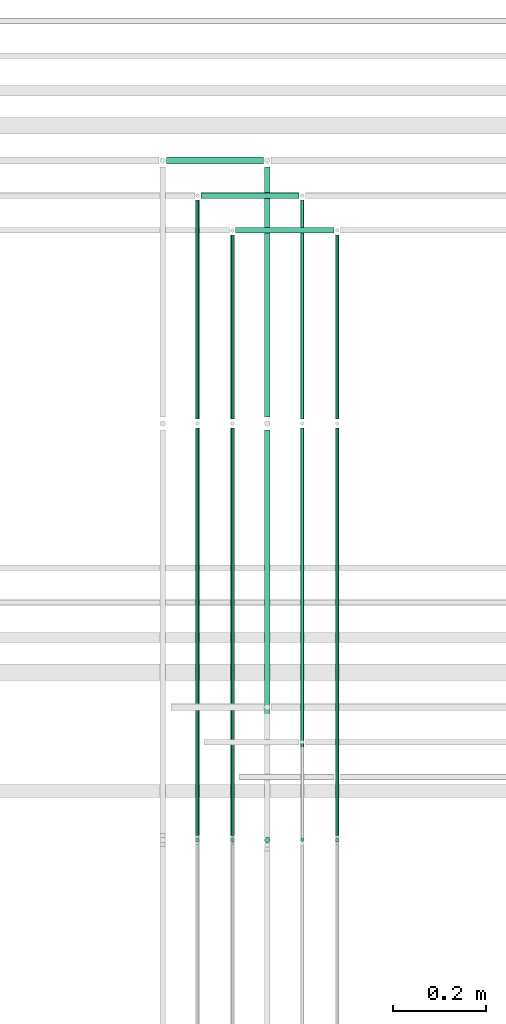
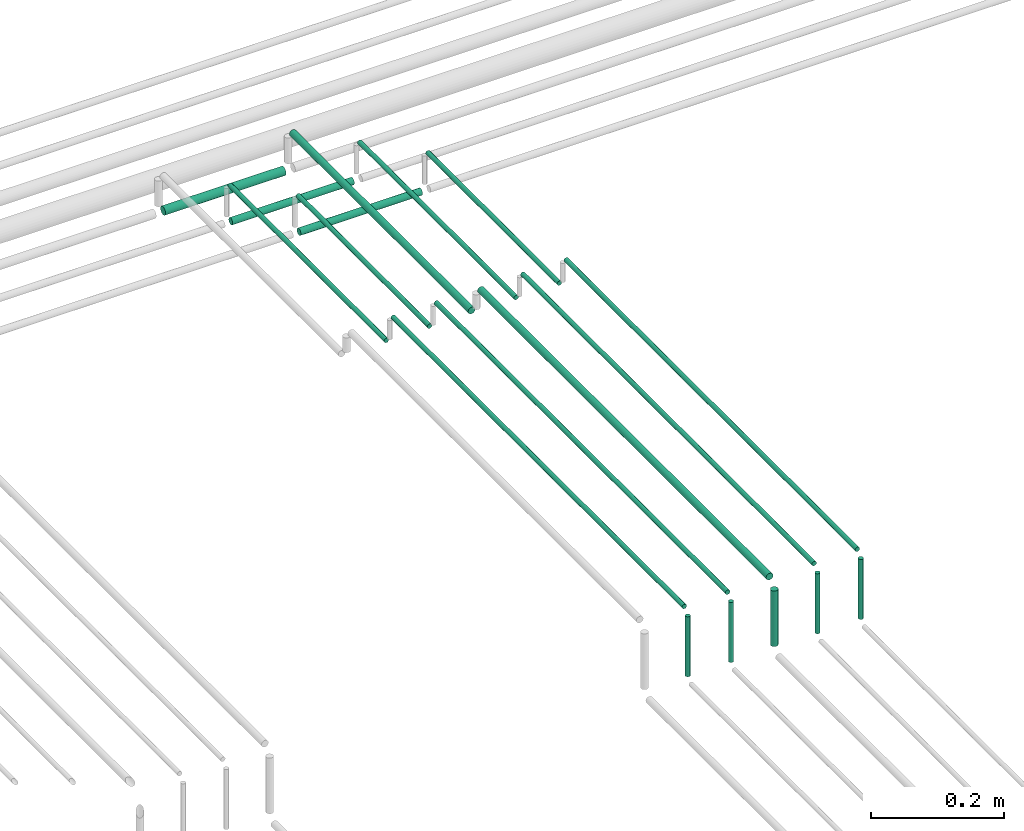
# One storey, part 192 of 331: 18 flow segments.
"""IFC2X3 building model written with IfcOpenShell, lengths in millimetres."""

import ifcopenshell
import ifcopenshell.guid

model = None  # the IFC model being written
_history = None  # IfcOwnerHistory: only IFC2X3 demands one
_inside = {}  # id of a spatial element -> (the spatial element, [elements in it])
_under = {}  # id of a project, library or spatial element -> (it, [spatial elements below it])
_declared = {}  # id of a project -> (the project, [libraries it declares])
_typed = {}  # id of a type object -> (the type object, [elements of that type])
_made_of = {}  # id of a material, layer set ... -> (it, [elements and type objects made of it])


def new_model(schema):
    """Start an empty IFC model of exactly this schema.

    Asked for "IFC4X3", IfcOpenShell would pick the latest addendum, in which some entities
    have other attributes; the version numbers below select the first issue.
    IFC2X3 requires an IfcOwnerHistory on every rooted entity: one is made here for all.
    """
    global model, _history
    if schema == "IFC4X3":
        model = ifcopenshell.file(schema_version=(4, 3, 0, 0))
    else:
        model = ifcopenshell.file(schema=schema)
    _inside.clear()
    _under.clear()
    _declared.clear()
    _typed.clear()
    _made_of.clear()
    _history = None
    if model.schema == "IFC2X3":
        org = make("IfcOrganization", Name="unknown")
        user = make(
            "IfcPersonAndOrganization",
            ThePerson=make("IfcPerson", FamilyName="unknown"),
            TheOrganization=org,
        )
        app = make(
            "IfcApplication",
            ApplicationDeveloper=org,
            Version="unknown",
            ApplicationFullName="unknown",
            ApplicationIdentifier="unknown",
        )
        _history = make(
            "IfcOwnerHistory",
            OwningUser=user,
            OwningApplication=app,
            ChangeAction="ADDED",
            CreationDate=0,
        )
    return model


def make(cls, **values):
    """One entity of the class cls with the attributes given. An attribute that is None is left unset."""
    return model.create_entity(
        cls, **{name: value for name, value in values.items() if value is not None}
    )


def entity(cls, *values):
    """Any entity or typed value of the class cls, its attributes in the order of the schema. None: left unset."""
    e = model.create_entity(cls)
    for i, value in enumerate(values):
        if value is not None:
            e[i] = value
    return e


def rooted(cls, **values):
    """An entity with a GlobalId (a new one), such as an element, a storey or a relation."""
    return make(cls, GlobalId=ifcopenshell.guid.new(), OwnerHistory=_history, **values)


def si_unit(unit_type, name, prefix=None):
    """IfcSIUnit, for example si_unit("LENGTHUNIT", "METRE", prefix="MILLI")."""
    return make("IfcSIUnit", UnitType=unit_type, Prefix=prefix, Name=name)


def converted_unit(unit_type, name, factor, base, dimensions=None, offset=None):
    """IfcConversionBasedUnit, such as the inch: factor (a typed value) times the base unit."""
    return make(
        "IfcConversionBasedUnit"
        if offset is None
        else "IfcConversionBasedUnitWithOffset",
        ConversionOffset=offset,
        Dimensions=None
        if dimensions is None
        else entity("IfcDimensionalExponents", *dimensions),
        UnitType=unit_type,
        Name=name,
        ConversionFactor=make(
            "IfcMeasureWithUnit", ValueComponent=factor, UnitComponent=base
        ),
    )


def derived_unit(unit_type, elements):
    """IfcDerivedUnit: a product of units, each with its exponent."""
    return make(
        "IfcDerivedUnit",
        Elements=[
            make("IfcDerivedUnitElement", Unit=unit, Exponent=power)
            for unit, power in elements
        ],
        UnitType=unit_type,
    )


def assignment(units):
    """IfcUnitAssignment: the units of a project."""
    return None if units is None else make("IfcUnitAssignment", Units=units)


def point(xyz):
    """IfcCartesianPoint."""
    return None if xyz is None else make("IfcCartesianPoint", Coordinates=xyz)


def direction(xyz):
    """IfcDirection."""
    return None if xyz is None else make("IfcDirection", DirectionRatios=xyz)


def frame(location, z_axis=None, x_axis=None):
    """IfcAxis2Placement3D, a coordinate frame: its origin and axes. An axis left out is left unset."""
    return make(
        "IfcAxis2Placement3D",
        Location=point(location),
        Axis=direction(z_axis),
        RefDirection=direction(x_axis),
    )


def frame_2d(location, x_axis=None):
    """IfcAxis2Placement2D, a coordinate frame in the plane: its origin and x axis."""
    return make(
        "IfcAxis2Placement2D", Location=point(location), RefDirection=direction(x_axis)
    )


def origin():
    """The frame at (0, 0, 0) with its axes left unset."""
    return frame((0.0, 0.0, 0.0))


def origin_2d_with_axis():
    """The frame at (0, 0) in the plane with the x axis (1, 0) written out."""
    return frame_2d((0.0, 0.0), x_axis=(1.0, 0.0))


def place(relative_to, where):
    """IfcLocalPlacement: puts the frame where relative to a parent placement (None: the world)."""
    return make(
        "IfcLocalPlacement", PlacementRelTo=relative_to, RelativePlacement=where
    )


def context(
    kind, dimensions, precision=None, world=None, true_north=None, identifier=None
):
    """IfcGeometricRepresentationContext, for example the 3D "Model" context."""
    return make(
        "IfcGeometricRepresentationContext",
        ContextIdentifier=identifier,
        ContextType=kind,
        CoordinateSpaceDimension=dimensions,
        Precision=precision,
        WorldCoordinateSystem=world,
        TrueNorth=true_north,
    )


def subcontext(parent, identifier, kind, view, scale=None):
    """IfcGeometricRepresentationSubContext, for example "Body" below "Model"."""
    return make(
        "IfcGeometricRepresentationSubContext",
        ContextIdentifier=identifier,
        ContextType=kind,
        ParentContext=parent,
        TargetScale=scale,
        TargetView=view,
    )


def project(units=None, contexts=None):
    """IfcProject with its units and contexts."""
    return rooted(
        "IfcProject",
        Name="project",
        RepresentationContexts=contexts,
        UnitsInContext=assignment(units),
    )


def spatial(cls, under=None, at=None, **own):
    """A site, building, storey or space (cls), placed at a placement, below another one or the project."""
    s = rooted(cls, ObjectPlacement=at, **own)
    if under is not None:
        _under.setdefault(under.id(), (under, []))[1].append(s)
    return s


def profile(cls, at=None, kind="AREA", **sizes):
    """A parametric profile (cls). Its sizes go by their IFC names, for example OverallWidth=200.0."""
    return make(cls, ProfileType=kind, Position=at, **sizes)


def circle(**sizes):
    """IfcCircleProfileDef."""
    return profile("IfcCircleProfileDef", **sizes)


def extrude(swept, where, along, depth):
    """IfcExtrudedAreaSolid: the profile swept, set in the frame where, extruded along a direction by depth."""
    return make(
        "IfcExtrudedAreaSolid",
        SweptArea=swept,
        Position=where,
        ExtrudedDirection=direction(along),
        Depth=depth,
    )


def shape(context_of_items, identifier, shape_type, items):
    """IfcShapeRepresentation: the items that make up one representation, for example the "Body"."""
    return make(
        "IfcShapeRepresentation",
        ContextOfItems=context_of_items,
        RepresentationIdentifier=identifier,
        RepresentationType=shape_type,
        Items=items,
    )


def made_of(thing, what):
    """Note that an element or type object is made of a material, layer set ...; save() writes the relation."""
    if what is not None:
        _made_of.setdefault(what.id(), (what, []))[1].append(thing)
    return thing


def type_object(cls, material=None, **own):
    """A type object (cls), such as IfcWallType, which elements share."""
    return made_of(rooted(cls, **own), material)


def element(
    cls,
    number,
    at=None,
    inside=None,
    cuts=None,
    type_object=None,
    material=None,
    context=None,
    identifier="Body",
    shape_type=None,
    held_by="IfcProductDefinitionShape",
    body=None,
    shapes=None,
    **own,
):
    """One element of the class cls, such as IfcWall. Its Tag is "e" and its number.

    at: its placement. inside: the storey or other place that contains it. cuts: it is an
    opening in that element (IfcRelVoidsElement). A single representation is given by context,
    identifier, shape_type and body (its items); several are given by shapes. held_by: the class
    of the entity that holds the representations. save() writes the other relations.
    """
    e = rooted(cls, Tag="e%d" % number, ObjectPlacement=at, **own)
    if body is not None:
        shapes = [shape(context, identifier, shape_type, body)]
    if shapes is not None:
        e.Representation = make(held_by, Representations=shapes)
    if inside is not None:
        _inside.setdefault(inside.id(), (inside, []))[1].append(e)
    if cuts is not None:
        rooted(
            "IfcRelVoidsElement", RelatingBuildingElement=cuts, RelatedOpeningElement=e
        )
    if type_object is not None:
        _typed.setdefault(type_object.id(), (type_object, []))[1].append(e)
    return made_of(e, material)


def aggregate(whole, parts):
    """IfcRelAggregates: a whole, such as a stair, and the parts it consists of."""
    return rooted("IfcRelAggregates", RelatingObject=whole, RelatedObjects=parts)


def save(model, path):
    """Write the relations noted so far, then the file.

    IfcRelAggregates (storeys below a building ...), IfcRelContainedInSpatialStructure (elements
    in a storey), IfcRelDefinesByType, IfcRelAssociatesMaterial and IfcRelDeclares: one each for
    every whole, place, type object, material and project.
    """
    for whole, parts in _under.values():
        aggregate(whole, parts)
    for where, things in _inside.values():
        rooted(
            "IfcRelContainedInSpatialStructure",
            RelatedElements=things,
            RelatingStructure=where,
        )
    for kind, things in _typed.values():
        rooted("IfcRelDefinesByType", RelatedObjects=things, RelatingType=kind)
    for what, things in _made_of.values():
        rooted("IfcRelAssociatesMaterial", RelatedObjects=things, RelatingMaterial=what)
    for by, libraries in _declared.values():
        rooted("IfcRelDeclares", RelatingContext=by, RelatedDefinitions=libraries)
    model.write(path)


model = new_model("IFC2X3")

# Units and contexts
model_context = context("Model", 3, precision=0.01, world=origin(), true_north=direction((6.12303176911189e-17, 1.0)))
body_context = subcontext(model_context, "Body", "Model", "MODEL_VIEW")
ifc_project = project(units=[si_unit("LENGTHUNIT", "METRE", prefix="MILLI"), si_unit("AREAUNIT", "SQUARE_METRE"), si_unit("VOLUMEUNIT", "CUBIC_METRE"), converted_unit("PLANEANGLEUNIT", "DEGREE", entity("IfcRatioMeasure", 0.0174532925199433), si_unit("PLANEANGLEUNIT", "RADIAN"), dimensions=[0, 0, 0, 0, 0, 0, 0]), si_unit("MASSUNIT", "GRAM", prefix="KILO"), derived_unit("MASSDENSITYUNIT", [(si_unit("MASSUNIT", "GRAM", prefix="KILO"), 1), (si_unit("LENGTHUNIT", "METRE"), -3)]), derived_unit("MOMENTOFINERTIAUNIT", [(si_unit("LENGTHUNIT", "METRE"), 4)]), si_unit("TIMEUNIT", "SECOND"), si_unit("FREQUENCYUNIT", "HERTZ"), si_unit("THERMODYNAMICTEMPERATUREUNIT", "DEGREE_CELSIUS"), derived_unit("THERMALTRANSMITTANCEUNIT", [(si_unit("MASSUNIT", "GRAM", prefix="KILO"), 1), (si_unit("THERMODYNAMICTEMPERATUREUNIT", "KELVIN"), -1), (si_unit("TIMEUNIT", "SECOND"), -3)]), derived_unit("VOLUMETRICFLOWRATEUNIT", [(si_unit("LENGTHUNIT", "METRE"), 3), (si_unit("TIMEUNIT", "SECOND"), -1)]), derived_unit("MASSFLOWRATEUNIT", [(si_unit("MASSUNIT", "GRAM", prefix="KILO"), 1), (si_unit("TIMEUNIT", "SECOND"), -1)]), derived_unit("ROTATIONALFREQUENCYUNIT", [(si_unit("TIMEUNIT", "SECOND"), -1)]), si_unit("ELECTRICCURRENTUNIT", "AMPERE"), si_unit("ELECTRICVOLTAGEUNIT", "VOLT"), si_unit("POWERUNIT", "WATT"), si_unit("FORCEUNIT", "NEWTON", prefix="KILO"), si_unit("ILLUMINANCEUNIT", "LUX"), si_unit("LUMINOUSFLUXUNIT", "LUMEN"), si_unit("LUMINOUSINTENSITYUNIT", "CANDELA"), derived_unit("USERDEFINED", [(si_unit("MASSUNIT", "GRAM", prefix="KILO"), -1), (si_unit("LENGTHUNIT", "METRE"), -2), (si_unit("TIMEUNIT", "SECOND"), 3), (si_unit("LUMINOUSFLUXUNIT", "LUMEN"), 1)]), derived_unit("LINEARVELOCITYUNIT", [(si_unit("LENGTHUNIT", "METRE"), 1), (si_unit("TIMEUNIT", "SECOND"), -1)]), si_unit("PRESSUREUNIT", "PASCAL"), derived_unit("USERDEFINED", [(si_unit("LENGTHUNIT", "METRE"), -2), (si_unit("MASSUNIT", "GRAM", prefix="KILO"), 1), (si_unit("TIMEUNIT", "SECOND"), -2)]), derived_unit("LINEARFORCEUNIT", [(si_unit("MASSUNIT", "GRAM", prefix="KILO"), 1), (si_unit("LENGTHUNIT", "METRE"), 1), (si_unit("TIMEUNIT", "SECOND"), -2), (si_unit("LENGTHUNIT", "METRE"), -1)]), derived_unit("PLANARFORCEUNIT", [(si_unit("MASSUNIT", "GRAM", prefix="KILO"), 1), (si_unit("LENGTHUNIT", "METRE"), 1), (si_unit("TIMEUNIT", "SECOND"), -2), (si_unit("LENGTHUNIT", "METRE"), -2)])], contexts=[model_context])

# Site, building, storey
site_placement = place(None, frame((0.0, -0.00077364408347762, 0.0)))
site = spatial("IfcSite", under=ifc_project, at=site_placement, CompositionType="ELEMENT")
building_placement = place(site_placement, origin())
building = spatial("IfcBuilding", under=site, at=building_placement, CompositionType="ELEMENT")
storey_placement = place(building_placement, origin())
storey = spatial("IfcBuildingStorey", under=building, at=storey_placement, CompositionType="ELEMENT", Elevation=0.0)

# Flow segments
pipe_segment_type = type_object("IfcPipeSegmentType", PredefinedType="NOTDEFINED")
flow_segment_1_placement = place(storey_placement, frame((44577.1659203727, 9467.404727764, 18442.4047277642)))
element("IfcFlowSegment", 1, at=flow_segment_1_placement, inside=storey, type_object=pipe_segment_type, context=body_context, shape_type="SweptSolid", body=[
    extrude(circle(Radius=6.0, at=frame_2d((-2.70716782324598e-11, -2.16573425859679e-12), x_axis=(1.0, 0.0))), frame((0.0, 7.59527223594269, 7.59527223591887), z_axis=(1.0, 0.0, 0.0), x_axis=(0.0, 1.0, 0.0)), (0.0, 0.0, 1.0), 211.00000000003),
])
flow_segment_2_placement = place(storey_placement, frame((44652.1659203727, 9392.40472776404, 18442.4047277641)))
element("IfcFlowSegment", 2, at=flow_segment_2_placement, inside=storey, type_object=pipe_segment_type, context=body_context, shape_type="SweptSolid", body=[
    extrude(circle(Radius=6.0, at=frame_2d((0.0, -2.16573425859679e-12), x_axis=(1.0, 0.0))), frame((0.0, 7.59527223591562, 7.59527223591887), z_axis=(1.0, 0.0, 0.0), x_axis=(0.0, 1.0, 0.0)), (0.0, 0.0, 1.0), 211.000000000021),
])
flow_segment_3_placement = place(storey_placement, frame((44864.5706481369, 8995.14880665494, 18519.4047277642)))
element("IfcFlowSegment", 3, at=flow_segment_3_placement, inside=storey, type_object=pipe_segment_type, context=body_context, shape_type="SweptSolid", body=[
    extrude(circle(Radius=4.0, at=origin_2d_with_axis()), frame((5.59527223591499, 0.0, 5.59527223591499), z_axis=(0.0, 1.0, 0.0), x_axis=(-1.0, 0.0, 0.0)), (0.0, 0.0, 1.0), 394.851193345022),
])
flow_segment_4_placement = place(storey_placement, frame((44864.5706481368, 8084.55353441896, 18460.0)))
element("IfcFlowSegment", 4, at=flow_segment_4_placement, inside=storey, type_object=pipe_segment_type, context=body_context, shape_type="SweptSolid", body=[
    extrude(circle(Radius=4.0, at=frame_2d((0.0, -1.08286712929839e-12), x_axis=(1.0, 0.0))), frame((5.59527223591499, 5.59527223591499, 0.0), z_axis=(0.0, 0.0, 1.0), x_axis=(-1.0, 0.0, 0.0)), (0.0, 0.0, 1.0), 110.000000000014),
])
flow_segment_5_placement = place(storey_placement, frame((44789.5706481368, 8084.55353441895, 18460.0)))
element("IfcFlowSegment", 5, at=flow_segment_5_placement, inside=storey, type_object=pipe_segment_type, context=body_context, shape_type="SweptSolid", body=[
    extrude(circle(Radius=4.0, at=origin_2d_with_axis()), frame((5.59527223591499, 5.59527223591607, 0.0)), (0.0, 0.0, 1.0), 110.00000000001),
])
flow_segment_6_placement = place(storey_placement, frame((44789.5706481368, 8100.14880665486, 18574.4047277641)))
element("IfcFlowSegment", 6, at=flow_segment_6_placement, inside=storey, type_object=pipe_segment_type, context=body_context, shape_type="SweptSolid", body=[
    extrude(circle(Radius=4.0, at=origin_2d_with_axis()), frame((5.59527223590633, 0.0, 5.59527223591499), z_axis=(0.0, 1.0, 0.0), x_axis=(1.0, 0.0, 0.0)), (0.0, 0.0, 1.0), 875.000000000085),
])
flow_segment_7_placement = place(storey_placement, frame((44712.5706481368, 8082.55353441903, 18464.0)))
element("IfcFlowSegment", 7, at=flow_segment_7_placement, inside=storey, type_object=pipe_segment_type, context=body_context, shape_type="SweptSolid", body=[
    extrude(circle(Radius=6.0, at=origin_2d_with_axis()), frame((7.59527223591454, 7.59527223591562, 0.0), z_axis=(0.0, 0.0, 1.0), x_axis=(-1.0, 0.0, 0.0)), (0.0, 0.0, 1.0), 102.000000000014),
])
flow_segment_8_placement = place(storey_placement, frame((44712.5706481368, 8104.14880665494, 18572.4047277641)))
element("IfcFlowSegment", 8, at=flow_segment_8_placement, inside=storey, type_object=pipe_segment_type, context=body_context, shape_type="SweptSolid", body=[
    extrude(circle(Radius=6.0, at=frame_2d((0.0, 2.16573425859679e-12), x_axis=(1.0, 0.0))), frame((7.59527223590587, 0.0, 7.59527223591887), z_axis=(0.0, 1.0, 0.0), x_axis=(1.0, 0.0, 0.0)), (0.0, 0.0, 1.0), 867.000000000012),
])
flow_segment_9_placement = place(storey_placement, frame((44639.5706481368, 8084.55353441903, 18460.0)))
element("IfcFlowSegment", 9, at=flow_segment_9_placement, inside=storey, type_object=pipe_segment_type, context=body_context, shape_type="SweptSolid", body=[
    extrude(circle(Radius=4.0, at=origin_2d_with_axis()), frame((5.59527223591499, 5.59527223591607, 0.0), z_axis=(0.0, 0.0, 1.0), x_axis=(-1.0, 0.0, 0.0)), (0.0, 0.0, 1.0), 110.000000000053),
])
flow_segment_10_placement = place(storey_placement, frame((44639.5706481368, 8995.14880665494, 18519.4047277642)))
element("IfcFlowSegment", 10, at=flow_segment_10_placement, inside=storey, type_object=pipe_segment_type, context=body_context, shape_type="SweptSolid", body=[
    extrude(circle(Radius=4.0, at=origin_2d_with_axis()), frame((5.59527223591499, 0.0, 5.59527223591716), z_axis=(0.0, 1.0, 0.0), x_axis=(-1.0, 0.0, 0.0)), (0.0, 0.0, 1.0), 394.851193345022),
])
flow_segment_11_placement = place(storey_placement, frame((44564.5706481368, 8084.55353441903, 18460.0)))
element("IfcFlowSegment", 11, at=flow_segment_11_placement, inside=storey, type_object=pipe_segment_type, context=body_context, shape_type="SweptSolid", body=[
    extrude(circle(Radius=4.0, at=origin_2d_with_axis()), frame((5.59527223591499, 5.59527223591607, 0.0), z_axis=(0.0, 0.0, 1.0), x_axis=(-1.0, 0.0, 0.0)), (0.0, 0.0, 1.0), 110.000000000036),
])
flow_segment_12_placement = place(storey_placement, frame((44564.5706481368, 8995.14880665494, 18519.4047277642)))
element("IfcFlowSegment", 12, at=flow_segment_12_placement, inside=storey, type_object=pipe_segment_type, context=body_context, shape_type="SweptSolid", body=[
    extrude(circle(Radius=4.0, at=origin_2d_with_axis()), frame((5.59527223591499, 0.0, 5.59527223591499), z_axis=(0.0, 1.0, 0.0), x_axis=(-1.0, 0.0, 0.0)), (0.0, 0.0, 1.0), 469.851193345038),
])
flow_segment_13_placement = place(storey_placement, frame((44503.1659203727, 9540.90472776404, 18440.9047277642)))
element("IfcFlowSegment", 13, at=flow_segment_13_placement, inside=storey, type_object=pipe_segment_type, context=body_context, shape_type="SweptSolid", body=[
    extrude(circle(Radius=7.5, at=origin_2d_with_axis()), frame((0.0, 9.09527223591636, 9.09527223591636), z_axis=(1.0, 0.0, 0.0), x_axis=(0.0, -1.0, 0.0)), (0.0, 0.0, 1.0), 209.000000000004),
])
flow_segment_14_placement = place(storey_placement, frame((44564.5706481368, 8100.14880665494, 18574.4047277641)))
element("IfcFlowSegment", 14, at=flow_segment_14_placement, inside=storey, type_object=pipe_segment_type, context=body_context, shape_type="SweptSolid", body=[
    extrude(circle(Radius=4.0, at=origin_2d_with_axis()), frame((5.59527223592365, 0.0, 5.59527223591499), z_axis=(0.0, 1.0, 0.0), x_axis=(1.0, 0.0, 0.0)), (0.0, 0.0, 1.0), 875.000000000011),
])
flow_segment_15_placement = place(storey_placement, frame((44639.5706481368, 8100.14880665493, 18574.4047277641)))
element("IfcFlowSegment", 15, at=flow_segment_15_placement, inside=storey, type_object=pipe_segment_type, context=body_context, shape_type="SweptSolid", body=[
    extrude(circle(Radius=4.0, at=origin_2d_with_axis()), frame((5.59527223591499, 0.0, 5.59527223591499), z_axis=(0.0, 1.0, 0.0), x_axis=(1.0, 0.0, 0.0)), (0.0, 0.0, 1.0), 875.000000000014),
])
flow_segment_16_placement = place(storey_placement, frame((44712.5706481368, 8999.14880665494, 18517.4047277642)))
element("IfcFlowSegment", 16, at=flow_segment_16_placement, inside=storey, type_object=pipe_segment_type, context=body_context, shape_type="SweptSolid", body=[
    extrude(circle(Radius=6.0, at=origin_2d_with_axis()), frame((7.59527223591454, 0.0, 7.5952722359167), z_axis=(0.0, 1.0, 0.0), x_axis=(-1.0, 0.0, 0.0)), (0.0, 0.0, 1.0), 536.85119334503),
])
flow_segment_17_placement = place(storey_placement, frame((44789.5706481368, 8995.14880665493, 18519.4047277642)))
element("IfcFlowSegment", 17, at=flow_segment_17_placement, inside=storey, type_object=pipe_segment_type, context=body_context, shape_type="SweptSolid", body=[
    extrude(circle(Radius=4.0, at=origin_2d_with_axis()), frame((5.59527223591499, 0.0, 5.59527223591499), z_axis=(0.0, 1.0, 0.0), x_axis=(1.0, 0.0, 0.0)), (0.0, 0.0, 1.0), 469.851193344991),
])
flow_segment_18_placement = place(storey_placement, frame((44864.5706481368, 8100.14880665486, 18574.4047277641)))
element("IfcFlowSegment", 18, at=flow_segment_18_placement, inside=storey, type_object=pipe_segment_type, context=body_context, shape_type="SweptSolid", body=[
    extrude(circle(Radius=4.0, at=origin_2d_with_axis()), frame((5.59527223591499, 0.0, 5.59527223591499), z_axis=(0.0, 1.0, 0.0), x_axis=(1.0, 0.0, 0.0)), (0.0, 0.0, 1.0), 875.000000000088),
])

save(model, "model.ifc")
